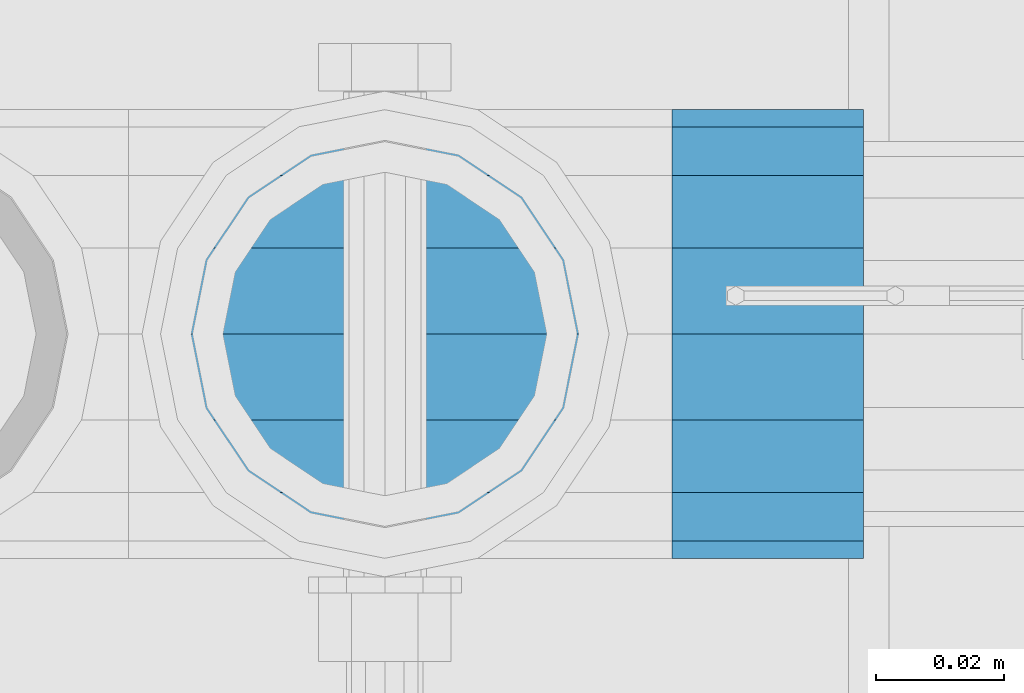
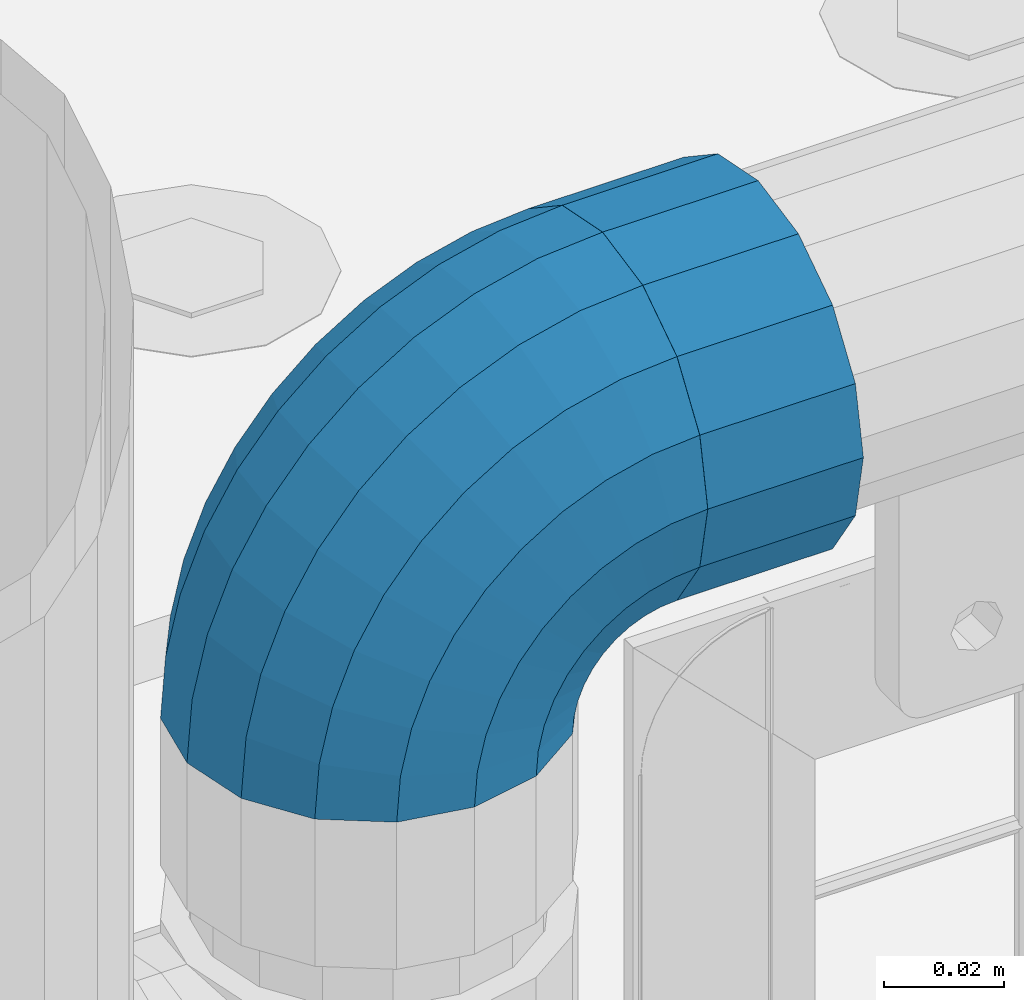
# One storey, part 118 of 208: 1 beam, 1 member.
"""IFC2X3 building model written with IfcOpenShell, lengths in millimetres."""

import ifcopenshell
import ifcopenshell.guid

model = None  # the IFC model being written
_history = None  # IfcOwnerHistory: only IFC2X3 demands one
_inside = {}  # id of a spatial element -> (the spatial element, [elements in it])
_under = {}  # id of a project, library or spatial element -> (it, [spatial elements below it])
_declared = {}  # id of a project -> (the project, [libraries it declares])
_typed = {}  # id of a type object -> (the type object, [elements of that type])
_made_of = {}  # id of a material, layer set ... -> (it, [elements and type objects made of it])


def new_model(schema):
    """Start an empty IFC model of exactly this schema.

    Asked for "IFC4X3", IfcOpenShell would pick the latest addendum, in which some entities
    have other attributes; the version numbers below select the first issue.
    IFC2X3 requires an IfcOwnerHistory on every rooted entity: one is made here for all.
    """
    global model, _history
    if schema == "IFC4X3":
        model = ifcopenshell.file(schema_version=(4, 3, 0, 0))
    else:
        model = ifcopenshell.file(schema=schema)
    _inside.clear()
    _under.clear()
    _declared.clear()
    _typed.clear()
    _made_of.clear()
    _history = None
    if model.schema == "IFC2X3":
        org = make("IfcOrganization", Name="unknown")
        user = make(
            "IfcPersonAndOrganization",
            ThePerson=make("IfcPerson", FamilyName="unknown"),
            TheOrganization=org,
        )
        app = make(
            "IfcApplication",
            ApplicationDeveloper=org,
            Version="unknown",
            ApplicationFullName="unknown",
            ApplicationIdentifier="unknown",
        )
        _history = make(
            "IfcOwnerHistory",
            OwningUser=user,
            OwningApplication=app,
            ChangeAction="ADDED",
            CreationDate=0,
        )
    return model


def make(cls, **values):
    """One entity of the class cls with the attributes given. An attribute that is None is left unset."""
    return model.create_entity(
        cls, **{name: value for name, value in values.items() if value is not None}
    )


def rooted(cls, **values):
    """An entity with a GlobalId (a new one), such as an element, a storey or a relation."""
    return make(cls, GlobalId=ifcopenshell.guid.new(), OwnerHistory=_history, **values)


def si_unit(unit_type, name, prefix=None):
    """IfcSIUnit, for example si_unit("LENGTHUNIT", "METRE", prefix="MILLI")."""
    return make("IfcSIUnit", UnitType=unit_type, Prefix=prefix, Name=name)


def assignment(units):
    """IfcUnitAssignment: the units of a project."""
    return None if units is None else make("IfcUnitAssignment", Units=units)


def point(xyz):
    """IfcCartesianPoint."""
    return None if xyz is None else make("IfcCartesianPoint", Coordinates=xyz)


def direction(xyz):
    """IfcDirection."""
    return None if xyz is None else make("IfcDirection", DirectionRatios=xyz)


def frame(location, z_axis=None, x_axis=None):
    """IfcAxis2Placement3D, a coordinate frame: its origin and axes. An axis left out is left unset."""
    return make(
        "IfcAxis2Placement3D",
        Location=point(location),
        Axis=direction(z_axis),
        RefDirection=direction(x_axis),
    )


def origin_with_axes():
    """The frame at (0, 0, 0) with the z axis (0, 0, 1) and the x axis (1, 0, 0) written out."""
    return frame((0.0, 0.0, 0.0), z_axis=(0.0, 0.0, 1.0), x_axis=(1.0, 0.0, 0.0))


def place(relative_to, where):
    """IfcLocalPlacement: puts the frame where relative to a parent placement (None: the world)."""
    return make(
        "IfcLocalPlacement", PlacementRelTo=relative_to, RelativePlacement=where
    )


def context(
    kind, dimensions, precision=None, world=None, true_north=None, identifier=None
):
    """IfcGeometricRepresentationContext, for example the 3D "Model" context."""
    return make(
        "IfcGeometricRepresentationContext",
        ContextIdentifier=identifier,
        ContextType=kind,
        CoordinateSpaceDimension=dimensions,
        Precision=precision,
        WorldCoordinateSystem=world,
        TrueNorth=true_north,
    )


def subcontext(parent, identifier, kind, view, scale=None):
    """IfcGeometricRepresentationSubContext, for example "Body" below "Model"."""
    return make(
        "IfcGeometricRepresentationSubContext",
        ContextIdentifier=identifier,
        ContextType=kind,
        ParentContext=parent,
        TargetScale=scale,
        TargetView=view,
    )


def project(units=None, contexts=None):
    """IfcProject with its units and contexts."""
    return rooted(
        "IfcProject",
        Name="project",
        RepresentationContexts=contexts,
        UnitsInContext=assignment(units),
    )


def spatial(cls, under=None, at=None, **own):
    """A site, building, storey or space (cls), placed at a placement, below another one or the project."""
    s = rooted(cls, ObjectPlacement=at, **own)
    if under is not None:
        _under.setdefault(under.id(), (under, []))[1].append(s)
    return s


def faces_of(points, faces, orient=None, outer=None):
    """IfcFace entities. A face is a list of loops; a loop is a list of indices into points, from 0.

    orient and outer hold one flag for each loop. By default every Orientation is true, the
    first loop of a face is its IfcFaceOuterBound and the others are IfcFaceBound.
    """
    made = []
    for i, loops in enumerate(faces):
        bounds = []
        for j, loop in enumerate(loops):
            is_outer = j == 0 if outer is None else outer[i][j]
            bounds.append(
                make(
                    "IfcFaceOuterBound" if is_outer else "IfcFaceBound",
                    Bound=make("IfcPolyLoop", Polygon=[points[k] for k in loop]),
                    Orientation=True if orient is None else orient[i][j],
                )
            )
        made.append(make("IfcFace", Bounds=bounds))
    return made


def faceted_brep(points, faces, orient=None, outer=None, voids=None):
    """IfcFacetedBrep: a solid bounded by flat faces; with voids (closed shells), ...WithVoids."""
    shared = [point(p) for p in points]
    hull = make("IfcClosedShell", CfsFaces=faces_of(shared, faces, orient, outer))
    if voids is None:
        return make("IfcFacetedBrep", Outer=hull)
    return make(
        "IfcFacetedBrepWithVoids",
        Outer=hull,
        Voids=[
            make(cls, CfsFaces=faces_of(shared, fs, o, b)) for cls, fs, o, b in voids
        ],
    )


def shape(context_of_items, identifier, shape_type, items):
    """IfcShapeRepresentation: the items that make up one representation, for example the "Body"."""
    return make(
        "IfcShapeRepresentation",
        ContextOfItems=context_of_items,
        RepresentationIdentifier=identifier,
        RepresentationType=shape_type,
        Items=items,
    )


def material(Name=None, Category=None):
    """IfcMaterial."""
    return make("IfcMaterial", Name=Name, Category=Category)


def made_of(thing, what):
    """Note that an element or type object is made of a material, layer set ...; save() writes the relation."""
    if what is not None:
        _made_of.setdefault(what.id(), (what, []))[1].append(thing)
    return thing


def type_object(cls, material=None, **own):
    """A type object (cls), such as IfcWallType, which elements share."""
    return made_of(rooted(cls, **own), material)


def element(
    cls,
    number,
    at=None,
    inside=None,
    cuts=None,
    type_object=None,
    material=None,
    context=None,
    identifier="Body",
    shape_type=None,
    held_by="IfcProductDefinitionShape",
    body=None,
    shapes=None,
    **own,
):
    """One element of the class cls, such as IfcWall. Its Tag is "e" and its number.

    at: its placement. inside: the storey or other place that contains it. cuts: it is an
    opening in that element (IfcRelVoidsElement). A single representation is given by context,
    identifier, shape_type and body (its items); several are given by shapes. held_by: the class
    of the entity that holds the representations. save() writes the other relations.
    """
    e = rooted(cls, Tag="e%d" % number, ObjectPlacement=at, **own)
    if body is not None:
        shapes = [shape(context, identifier, shape_type, body)]
    if shapes is not None:
        e.Representation = make(held_by, Representations=shapes)
    if inside is not None:
        _inside.setdefault(inside.id(), (inside, []))[1].append(e)
    if cuts is not None:
        rooted(
            "IfcRelVoidsElement", RelatingBuildingElement=cuts, RelatedOpeningElement=e
        )
    if type_object is not None:
        _typed.setdefault(type_object.id(), (type_object, []))[1].append(e)
    return made_of(e, material)


def aggregate(whole, parts):
    """IfcRelAggregates: a whole, such as a stair, and the parts it consists of."""
    return rooted("IfcRelAggregates", RelatingObject=whole, RelatedObjects=parts)


def save(model, path):
    """Write the relations noted so far, then the file.

    IfcRelAggregates (storeys below a building ...), IfcRelContainedInSpatialStructure (elements
    in a storey), IfcRelDefinesByType, IfcRelAssociatesMaterial and IfcRelDeclares: one each for
    every whole, place, type object, material and project.
    """
    for whole, parts in _under.values():
        aggregate(whole, parts)
    for where, things in _inside.values():
        rooted(
            "IfcRelContainedInSpatialStructure",
            RelatedElements=things,
            RelatingStructure=where,
        )
    for kind, things in _typed.values():
        rooted("IfcRelDefinesByType", RelatedObjects=things, RelatingType=kind)
    for what, things in _made_of.values():
        rooted("IfcRelAssociatesMaterial", RelatedObjects=things, RelatingMaterial=what)
    for by, libraries in _declared.values():
        rooted("IfcRelDeclares", RelatingContext=by, RelatedDefinitions=libraries)
    model.write(path)


model = new_model("IFC2X3")

# Units and contexts
model_context = context("Model", 3, precision=1e-05, world=origin_with_axes())
body_context = subcontext(model_context, "Body", "Model", "MODEL_VIEW")
ifc_project = project(units=[si_unit("LENGTHUNIT", "METRE", prefix="MILLI"), si_unit("AREAUNIT", "SQUARE_METRE"), si_unit("VOLUMEUNIT", "CUBIC_METRE"), si_unit("MASSUNIT", "GRAM", prefix="KILO"), si_unit("TIMEUNIT", "SECOND"), si_unit("PLANEANGLEUNIT", "RADIAN"), si_unit("SOLIDANGLEUNIT", "STERADIAN"), si_unit("THERMODYNAMICTEMPERATUREUNIT", "DEGREE_CELSIUS"), si_unit("LUMINOUSINTENSITYUNIT", "LUMEN")], contexts=[model_context])

# Site, building, storey
site_placement = place(None, origin_with_axes())
site = spatial("IfcSite", under=ifc_project, at=site_placement, CompositionType="ELEMENT")
building_placement = place(site_placement, origin_with_axes())
building = spatial("IfcBuilding", under=site, at=building_placement, Name="Standard", CompositionType="ELEMENT")
storey_placement = place(building_placement, origin_with_axes())
storey = spatial("IfcBuildingStorey", under=building, at=storey_placement, Name="Undefined", CompositionType="ELEMENT", Elevation=0.0)

# Beam
ifc_material = material(Name="Misc_Undefined")
beam_type = type_object("IfcBeamType", PredefinedType="NOTDEFINED")
beam_placement = place(storey_placement, frame((-41784.0, 4664.5, 969.849999999999), z_axis=(0.0, 0.0, 1.0), x_axis=(1.0, 0.0, 0.0)))
element("IfcBeam", 1, at=beam_placement, inside=storey, type_object=beam_type, material=ifc_material, context=body_context, shape_type="Brep", body=[
    faceted_brep([(0.0, -30.3500000000004, 0.0), (0.0, -28.0397438117179, 11.6144421722784), (30.0, -28.0397438117179, 11.6144421722805), (30.0, -30.3500000000004, 0.0), (0.0, -21.4606908090118, 21.4606908090136), (30.0, -21.4606908090118, 21.4606908090117), (0.0, -11.6144421722802, 28.0397438117143), (30.0, -11.6144421722802, 28.0397438117175), (0.0, 0.0, 30.3499999999985), (30.0, 0.0, 30.35), (0.0, 11.6144421722802, 28.0397438117143), (30.0, 11.6144421722802, 28.0397438117175), (0.0, 21.4606908090118, 21.4606908090136), (30.0, 21.4606908090118, 21.4606908090117), (0.0, 28.0397438117179, 11.6144421722784), (30.0, 28.0397438117179, 11.6144421722805), (0.0, 30.3500000000004, 0.0), (30.0, 30.3500000000004, 0.0), (0.0, 28.0397438117179, -11.6144421722784), (30.0, 28.0397438117179, -11.6144421722805), (0.0, 21.4606908090118, -21.4606908090136), (30.0, 21.4606908090118, -21.4606908090117), (0.0, 11.6144421722802, -28.0397438117143), (30.0, 11.6144421722802, -28.0397438117175), (0.0, 0.0, -30.3499999999985), (30.0, 0.0, -30.35), (0.0, -11.6144421722802, -28.0397438117143), (30.0, -11.6144421722802, -28.0397438117175), (0.0, -21.4606908090118, -21.4606908090136), (30.0, -21.4606908090118, -21.4606908090117), (0.0, -28.0397438117179, -11.6144421722784), (30.0, -28.0397438117179, -11.6144421722805), (0.0, -35.1499999999996, 0.0), (0.0, -32.4743655677721, -13.4513226476338), (30.0, -32.4743655677721, -13.4513226476329), (30.0, -35.1499999999996, 0.0), (0.0, -24.8548033587067, -24.8548033587067), (30.0, -24.8548033587067, -24.8548033587072), (0.0, -13.4513226476329, -32.4743655677739), (30.0, -13.4513226476329, -32.4743655677717), (0.0, 0.0, -35.1499999999996), (30.0, 0.0, -35.15), (0.0, 13.4513226476329, -32.4743655677739), (30.0, 13.4513226476329, -32.4743655677717), (0.0, 24.8548033587067, -24.8548033587067), (30.0, 24.8548033587067, -24.8548033587072), (0.0, 32.4743655677721, -13.4513226476338), (30.0, 32.4743655677721, -13.4513226476329), (0.0, 35.1499999999996, 0.0), (30.0, 35.1499999999996, 0.0), (0.0, 32.4743655677721, 13.4513226476338), (30.0, 32.4743655677721, 13.4513226476329), (0.0, 24.8548033587067, 24.8548033587067), (30.0, 24.8548033587067, 24.8548033587072), (0.0, 13.4513226476329, 32.4743655677739), (30.0, 13.4513226476329, 32.4743655677717), (0.0, 0.0, 35.1499999999996), (30.0, 0.0, 35.15), (0.0, -13.4513226476329, 32.4743655677739), (30.0, -13.4513226476329, 32.4743655677717), (0.0, -24.8548033587067, 24.8548033587067), (30.0, -24.8548033587067, 24.8548033587072), (0.0, -32.4743655677721, 13.4513226476338), (30.0, -32.4743655677721, 13.4513226476329)], [[[0, 1, 2, 3]], [[1, 4, 5, 2]], [[4, 6, 7, 5]], [[6, 8, 9, 7]], [[8, 10, 11, 9]], [[10, 12, 13, 11]], [[12, 14, 15, 13]], [[14, 16, 17, 15]], [[16, 18, 19, 17]], [[18, 20, 21, 19]], [[20, 22, 23, 21]], [[22, 24, 25, 23]], [[24, 26, 27, 25]], [[26, 28, 29, 27]], [[28, 30, 31, 29]], [[30, 0, 3, 31]], [[32, 33, 34, 35]], [[33, 36, 37, 34]], [[36, 38, 39, 37]], [[38, 40, 41, 39]], [[40, 42, 43, 41]], [[42, 44, 45, 43]], [[44, 46, 47, 45]], [[46, 48, 49, 47]], [[48, 50, 51, 49]], [[50, 52, 53, 51]], [[52, 54, 55, 53]], [[54, 56, 57, 55]], [[56, 58, 59, 57]], [[58, 60, 61, 59]], [[60, 62, 63, 61]], [[62, 32, 35, 63]], [[37, 39, 41, 43, 45, 47, 49, 51, 53, 55, 57, 59, 61, 63, 35, 34], [5, 7, 9, 11, 13, 15, 17, 19, 21, 23, 25, 27, 29, 31, 3, 2]], [[62, 60, 58, 56, 54, 52, 50, 48, 46, 44, 42, 40, 38, 36, 33, 32], [30, 28, 26, 24, 22, 20, 18, 16, 14, 12, 10, 8, 6, 4, 1, 0]]]),
])

# Member
member_type = type_object("IfcMemberType", PredefinedType="NOTDEFINED")
member_placement = place(storey_placement, frame((-41829.0, 4664.5, 924.849999999999), z_axis=(-0.707106781186548, 0.0, 0.707106781186548), x_axis=(0.707106781186539, -1.49999999888231e-07, 0.70710678118654)))
element("IfcMember", 2, at=member_placement, inside=storey, type_object=member_type, material=ifc_material, context=body_context, shape_type="Brep", body=[
    faceted_brep([(0.0, -35.1499999999996, 0.0), (9.51152146007371, -32.4743655677721, -9.51152146006643), (13.2759578763435, -32.4743655677721, -6.29638902527222), (5.3694688002397, -35.1499999999996, 4.58595959348168), (17.5750000000044, -24.8548033587067, -17.5749999999971), (19.9787556631163, -24.8548033587067, -15.5219987155615), (22.9628441077075, -13.4513226476329, -22.9628441076966), (24.4574219585302, -13.4513226476329, -21.6863540323902), (24.854803358714, 0.0, -24.8548033587031), (26.0301204183197, 0.0, -23.8509877588003), (22.9628441077075, 13.4513226476329, -22.9628441076966), (24.4574219585302, 13.4513226476329, -21.6863540323902), (17.5750000000044, 24.8548033587067, -17.5749999999971), (19.9787556631163, 24.8548033587067, -15.5219987155615), (9.51152146007371, 32.4743655677721, -9.51152146006643), (13.2759578763435, 32.4743655677721, -6.29638902527222), (0.0, 35.1499999999996, 0.0), (5.3694688002397, 35.1499999999996, 4.58595959348168), (-9.51152146006643, 32.4743655677721, 9.51152146007371), (-2.53702027587133, 32.4743655677721, 15.4683082122356), (-17.5749999999935, 24.8548033587067, 17.5750000000044), (-9.23981806264055, 24.8548033587067, 24.6939179025248), (-22.9628441076966, 13.4513226476329, 22.9628441077039), (-13.7184843580508, 13.4513226476329, 30.8582732193536), (-24.8548033587031, 0.0, 24.854803358714), (-15.2911828178439, 0.0, 33.02290694576), (-22.9628441076966, -13.4513226476329, 22.9628441077039), (-13.7184843580508, -13.4513226476329, 30.8582732193536), (-17.5749999999935, -24.8548033587067, 17.5750000000044), (-9.23981806264055, -24.8548033587067, 24.6939179025248), (-9.51152146006643, -32.4743655677721, 9.51152146007371), (-2.53702027587133, -32.4743655677721, 15.4683082122356), (0.0, -30.3500000000004, 0.0), (-8.21265081971433, -28.0397438117179, 8.21265081972524), (-1.45732902223244, -28.0397438117179, 13.9822406910389), (5.3694688002397, -30.3500000000004, 4.58595959348168), (-15.1749999999956, -21.4606908090118, 15.1750000000029), (-7.24480876130838, -21.4606908090118, 21.9480231689995), (-19.8270929919963, -11.6144421722802, 19.8270929920036), (-11.1118790903529, -11.6144421722802, 27.2705888550809), (-21.4606908090063, 0.0, 21.4606908090136), (-12.46981360684, 0.0, 29.139625372758), (-19.8270929919963, 11.6144421722802, 19.8270929920036), (-11.1118790903529, 11.6144421722802, 27.2705888550809), (-15.1749999999956, 21.4606908090118, 15.1750000000029), (-7.24480876130838, 21.4606908090118, 21.9480231689995), (-8.21265081971433, 28.0397438117179, 8.21265081972524), (-1.45732902223244, 28.0397438117179, 13.9822406910389), (0.0, 30.3500000000004, 0.0), (5.3694688002397, 30.3500000000004, 4.58595959348168), (8.21265081972524, 28.0397438117179, -8.21265081971433), (12.1962666227082, 28.0397438117179, -4.81032150407918), (15.1750000000029, 21.4606908090118, -15.1749999999956), (17.9837463617841, 21.4606908090118, -12.7761039820325), (19.8270929920036, 11.6144421722802, -19.8270929919963), (21.850816690825, 11.6144421722802, -18.0986696681175), (21.4606908090136, 0.0, -21.4606908090063), (23.2087512073158, 0.0, -19.9677061857983), (19.8270929920036, -11.6144421722802, -19.8270929919963), (21.850816690825, -11.6144421722802, -18.0986696681175), (15.1750000000029, -21.4606908090118, -15.1749999999956), (17.9837463617841, -21.4606908090118, -12.7761039820325), (8.21265081972524, -28.0397438117179, -8.21265081971433), (12.1962666227082, -28.0397438117179, -4.81032150407918), (17.4970053560755, -32.4743655677721, -3.70972780291777), (11.3902326651187, -35.1499999999996, 8.27548843508339), (22.6740772628655, -24.8548033587067, -13.870303514941), (26.1332861179544, -13.4513226476329, -20.6593831546779), (27.3479987309656, 0.0, -23.0433908901359), (26.1332861179544, 13.4513226476329, -20.6593831546779), (22.6740772628655, 24.8548033587067, -13.870303514941), (17.4970053560755, 32.4743655677721, -3.70972780291777), (11.3902326651187, 35.1499999999996, 8.27548843508339), (5.28345997416181, 32.4743655677721, 20.2607046730918), (0.106388067368243, 24.8548033587067, 30.4212803851115), (-3.3528207877207, 13.4513226476329, 37.2103600248483), (-4.56753340072828, 0.0, 39.59436776031), (-3.3528207877207, -13.4513226476329, 37.2103600248483), (0.106388067368243, -24.8548033587067, 30.4212803851115), (5.28345997416181, -32.4743655677721, 20.2607046730918), (6.11738625912767, -28.0397438117179, 18.6240321853948), (11.3902326651187, -30.3500000000004, 8.27548843508339), (1.64728291998108, -21.4606908090118, 27.3971039595053), (-1.33954464053022, -11.6144421722802, 33.2590831078996), (-2.38837900197541, 0.0, 35.3175364441995), (-1.33954464053022, 11.6144421722802, 33.2590831078996), (1.64728291998108, 21.4606908090118, 27.3971039595053), (6.11738625912767, 28.0397438117179, 18.6240321853948), (11.3902326651187, 30.3500000000004, 8.27548843508339), (16.663079071106, 28.0397438117179, -2.07305531522434), (21.1331824102563, 21.4606908090118, -10.8461270893349), (24.1200099707712, 11.6144421722802, -16.7081062377256), (25.1688443322128, 0.0, -18.7665595740327), (24.1200099707712, -11.6144421722802, -16.7081062377256), (21.1331824102563, -21.4606908090118, -10.8461270893349), (16.663079071106, -28.0397438117179, -2.07305531522434), (22.0707277014626, -32.4743655677721, -1.81522997692809), (17.9140404065256, -35.1499999999996, 10.9777380798914), (25.5945970362154, -24.8548033587067, -12.6605846156417), (27.9491712485142, -13.4513226476329, -19.9072189058897), (28.7759877588032, 0.0, -22.4518984678834), (27.9491712485142, 13.4513226476329, -19.9072189058897), (25.5945970362154, 24.8548033587067, -12.6605846156417), (22.0707277014626, 32.4743655677721, -1.81522997692809), (17.9140404065256, 35.1499999999996, 10.9777380798914), (13.7573531115886, 32.4743655677721, 23.7707061367109), (10.2334837768358, 24.8548033587067, 34.6160607754246), (7.87890956454066, 13.4513226476329, 41.8626950656726), (7.05209305424796, 0.0, 44.4073746276663), (7.87890956454066, -13.4513226476329, 41.8626950656726), (10.2334837768358, -24.8548033587067, 34.6160607754246), (13.7573531115886, -32.4743655677721, 23.7707061367109), (14.3249803951076, -28.0397438117179, 22.023728990971), (17.9140404065256, -30.3500000000004, 10.9777380798914), (11.2823222355146, -21.4606908090118, 31.3880679180002), (9.2492830507872, -11.6144421722802, 37.6451191472734), (8.53537462724489, 0.0, 39.8423033494473), (9.2492830507872, 11.6144421722802, 37.6451191472734), (11.2823222355146, 21.4606908090118, 31.3880679180002), (14.3249803951076, 28.0397438117179, 22.023728990971), (17.9140404065256, 30.3500000000004, 10.9777380798914), (21.5031004179436, 28.0397438117179, -0.0682528311917849), (24.5457585775366, 21.4606908090118, -9.43259175821368), (26.5787977622676, 11.6144421722802, -15.6896429874905), (27.2927061858063, 0.0, -17.8868271896645), (26.5787977622676, -11.6144421722802, -15.6896429874905), (24.5457585775366, -21.4606908090118, -9.43259175821368), (21.5031004179436, -28.0397438117179, -0.0682528311917849), (26.8845046890528, -32.4743655677721, -0.659544371261291), (24.7802542265854, -35.1499999999996, 12.6261701733893), (28.6684020936882, -24.8548033587067, -11.9226293117899), (29.860364231703, -13.4513226476329, -19.4483820661189), (30.2789256727519, 0.0, -22.0910749985305), (29.860364231703, 13.4513226476329, -19.4483820661189), (28.6684020936882, 24.8548033587067, -11.9226293117899), (26.8845046890528, 32.4743655677721, -0.659544371261291), (24.7802542265854, 35.1499999999996, 12.6261701733893), (22.6760037641179, 32.4743655677721, 25.9118847180434), (20.8921063594898, 24.8548033587067, 37.1749696585721), (19.7001442214714, 13.4513226476329, 44.7007224129011), (19.2815827804225, 0.0, 47.343415345309), (19.7001442214714, -13.4513226476329, 44.7007224129011), (20.8921063594898, -24.8548033587067, 37.1749696585721), (22.6760037641179, -32.4743655677721, 25.9118847180434), (22.9633551786246, -28.0397438117179, 24.0976192894668), (24.7802542265854, -30.3500000000004, 12.6261701733893), (21.4230625404853, -21.4606908090118, 33.8226442665691), (20.3938719035395, -11.6144421722802, 40.3206982094998), (20.0324682126193, 0.0, 42.6025113104552), (20.3938719035395, 11.6144421722802, 40.3206982094998), (21.4230625404853, 21.4606908090118, 33.8226442665691), (22.9633551786246, 28.0397438117179, 24.0976192894668), (24.7802542265854, 30.3500000000004, 12.6261701733893), (26.5971532745498, 28.0397438117179, 1.15472105731169), (28.1374459126891, 21.4606908090118, -8.5703039197906), (29.1666365496385, 11.6144421722802, -15.0683578627177), (29.5280402405588, 0.0, -17.350170963673), (29.1666365496385, -11.6144421722802, -15.0683578627177), (28.1374459126891, -21.4606908090118, -8.5703039197906), (26.5971532745498, -28.0397438117179, 1.15472105731169), (31.8198051533982, -32.4743655677721, -0.271127801024704), (31.8198051533982, -35.1499999999996, 13.1801948466091), (31.8198051533982, -24.8548033587067, -11.6746085120976), (31.8198051533982, -13.4513226476329, -19.2941707211648), (31.8198051533982, 0.0, -21.9698051533924), (31.8198051533982, 13.4513226476329, -19.2941707211648), (31.8198051533982, 24.8548033587067, -11.6746085120976), (31.8198051533982, 32.4743655677721, -0.271127801024704), (31.8198051533982, 35.1499999999996, 13.1801948466091), (31.8198051533982, 32.4743655677721, 26.6315174942429), (31.8198051533982, 24.8548033587067, 38.0349982053158), (31.8198051533946, 13.4513226476329, 45.654560414383), (31.8198051534018, 0.0, 48.3301948466105), (31.8198051533946, -13.4513226476329, 45.654560414383), (31.8198051533982, -24.8548033587067, 38.0349982053158), (31.8198051533982, -32.4743655677721, 26.6315174942429), (31.8198051533982, -28.0397438117179, 24.7946370188874), (31.8198051533982, -30.3500000000004, 13.1801948466091), (31.8198051533982, -21.4606908090118, 34.6408856556227), (31.8198051533982, -11.6144421722802, 41.219938658327), (31.8198051533982, 0.0, 43.5301948466113), (31.8198051533982, 11.6144421722802, 41.219938658327), (31.8198051533982, 21.4606908090118, 34.6408856556227), (31.8198051533982, 28.0397438117179, 24.7946370188874), (31.8198051533982, 30.3500000000004, 13.1801948466091), (31.8198051533946, 28.0397438117179, 1.56575267433072), (31.8198051533982, 21.4606908090118, -8.28049596240453), (31.8198051533982, 11.6144421722802, -14.8595489651088), (31.8198051533982, 0.0, -17.1698051533895), (31.8198051533982, -11.6144421722802, -14.8595489651088), (31.8198051533982, -21.4606908090118, -8.28049596240453), (31.8198051533946, -28.0397438117179, 1.56575267433072), (36.7551056177435, -32.4743655677721, -0.659544371261291), (38.859356080211, -35.1499999999996, 12.6261701733929), (34.9712082131082, -24.8548033587067, -11.9226293117899), (33.7792460750898, -13.4513226476329, -19.4483820661189), (33.3606846340444, 0.0, -22.0910749985269), (33.7792460750898, 13.4513226476329, -19.4483820661189), (34.9712082131082, 24.8548033587067, -11.9226293117899), (36.7551056177435, 32.4743655677721, -0.659544371261291), (38.859356080211, 35.1499999999996, 12.6261701733929), (40.9636065426712, 32.4743655677721, 25.9118847180434), (42.7475039473065, 24.8548033587067, 37.1749696585684), (43.939466085325, 13.4513226476329, 44.7007224129047), (44.3580275263703, 0.0, 47.343415345309), (43.939466085325, -13.4513226476329, 44.7007224129047), (42.7475039473065, -24.8548033587067, 37.1749696585684), (40.9636065426712, -32.4743655677721, 25.9118847180434), (40.6762551281718, -28.0397438117179, 24.0976192894668), (38.859356080211, -30.3500000000004, 12.6261701733929), (42.2165477663111, -21.4606908090118, 33.8226442665691), (43.2457384032568, -11.6144421722802, 40.3206982094998), (43.6071420941771, 0.0, 42.6025113104515), (43.2457384032568, 11.6144421722802, 40.3206982094998), (42.2165477663111, 21.4606908090118, 33.8226442665691), (40.6762551281718, 28.0397438117179, 24.0976192894668), (38.859356080211, 30.3500000000004, 12.6261701733929), (37.0424570322466, 28.0397438117179, 1.15472105731169), (35.5021643941072, 21.4606908090118, -8.5703039197906), (34.4729737571579, 11.6144421722802, -15.0683578627177), (34.1115700662376, 0.0, -17.350170963673), (34.4729737571579, -11.6144421722802, -15.0683578627177), (35.5021643941072, -21.4606908090118, -8.5703039197906), (37.0424570322466, -28.0397438117179, 1.15472105731169), (41.5688826053338, -32.4743655677721, -1.81522997692809), (45.7255699002708, -35.1499999999996, 10.9777380798914), (38.045013270581, -24.8548033587067, -12.6605846156417), (35.6904390582822, -13.4513226476329, -19.9072189058897), (34.8636225479895, 0.0, -22.4518984678834), (35.6904390582822, 13.4513226476329, -19.9072189058897), (38.045013270581, 24.8548033587067, -12.6605846156417), (41.5688826053338, 32.4743655677721, -1.81522997692809), (45.7255699002708, 35.1499999999996, 10.9777380798914), (49.8822571952114, 32.4743655677721, 23.7707061367109), (53.4061265299606, 24.8548033587067, 34.6160607754246), (55.7607007422557, 13.4513226476329, 41.8626950656726), (56.5875172525484, 0.0, 44.4073746276699), (55.7607007422557, -13.4513226476329, 41.8626950656726), (53.4061265299606, -24.8548033587067, 34.6160607754246), (49.8822571952114, -32.4743655677721, 23.7707061367109), (49.3146299116925, -28.0397438117179, 22.0237289909746), (45.7255699002708, -30.3500000000004, 10.9777380798914), (52.3572880712818, -21.4606908090118, 31.3880679179965), (54.3903272560092, -11.6144421722802, 37.6451191472697), (55.1042356795515, 0.0, 39.8423033494473), (54.3903272560092, 11.6144421722802, 37.6451191472697), (52.3572880712818, 21.4606908090118, 31.3880679179965), (49.3146299116925, 28.0397438117179, 22.0237289909746), (45.7255699002708, 30.3500000000004, 10.9777380798914), (42.1365098888527, 28.0397438117179, -0.0682528311917849), (39.0938517292598, 21.4606908090118, -9.43259175821368), (37.0608125445287, 11.6144421722802, -15.6896429874905), (36.3469041209937, 0.0, -17.8868271896645), (37.0608125445287, -11.6144421722802, -15.6896429874905), (39.0938517292598, -21.4606908090118, -9.43259175821368), (42.1365098888527, -28.0397438117179, -0.0682528311917849), (46.1426049507245, -32.4743655677721, -3.70972780291777), (52.2493776416777, -35.1499999999996, 8.27548843508339), (40.9655330439309, -24.8548033587067, -13.870303514941), (37.506324188842, -13.4513226476329, -20.6593831546743), (36.2916115758308, 0.0, -23.0433908901359), (37.506324188842, 13.4513226476329, -20.6593831546743), (40.9655330439309, 24.8548033587067, -13.870303514941), (46.1426049507245, 32.4743655677721, -3.70972780291777), (52.2493776416777, 35.1499999999996, 8.27548843508339), (58.3561503326309, 32.4743655677721, 20.2607046730918), (63.5332222394245, 24.8548033587067, 30.4212803851151), (66.9924310945171, 13.4513226476329, 37.2103600248483), (68.207143707521, 0.0, 39.5943677603063), (66.9924310945171, -13.4513226476329, 37.2103600248483), (63.5332222394245, -24.8548033587067, 30.4212803851151), (58.3561503326309, -32.4743655677721, 20.2607046730918), (57.5222240476687, -28.0397438117179, 18.6240321853984), (52.2493776416777, -30.3500000000004, 8.27548843508339), (61.9923273868153, -21.4606908090118, 27.3971039595053), (64.9791549473266, -11.6144421722802, 33.259083107896), (66.0279893087718, 0.0, 35.3175364442068), (64.9791549473266, 11.6144421722802, 33.259083107896), (61.9923273868153, 21.4606908090118, 27.3971039595053), (57.5222240476687, 28.0397438117179, 18.6240321853984), (52.2493776416777, 30.3500000000004, 8.27548843508339), (46.9765312356867, 28.0397438117179, -2.0730553152207), (42.5064278965401, 21.4606908090118, -10.8461270893349), (39.5196003360288, 11.6144421722802, -16.7081062377256), (38.4707659745836, 0.0, -18.7665595740327), (39.5196003360288, -11.6144421722802, -16.7081062377256), (42.5064278965401, -21.4606908090118, -10.8461270893349), (46.9765312356867, -28.0397438117179, -2.0730553152207), (50.3636524304529, -32.4743655677721, -6.29638902527222), (58.2701415065603, -35.1499999999996, 4.58595959348168), (43.6608546436801, -24.8548033587067, -15.5219987155615), (39.1821883482698, -13.4513226476329, -21.6863540323902), (37.6094898884767, 0.0, -23.8509877587967), (39.1821883482698, 13.4513226476329, -21.6863540323902), (43.6608546436801, 24.8548033587067, -15.5219987155615), (50.3636524304529, 32.4743655677721, -6.29638902527222), (58.2701415065603, 35.1499999999996, 4.58595959348168), (66.1766305826677, 32.4743655677721, 15.4683082122392), (72.8794283694369, 24.8548033587067, 24.6939179025212), (77.3580946648508, 13.4513226476329, 30.8582732193536), (78.9307931246403, 0.0, 33.02290694576), (77.3580946648508, -13.4513226476329, 30.8582732193536), (72.8794283694369, -24.8548033587067, 24.6939179025212), (66.1766305826677, -32.4743655677721, 15.4683082122392), (65.0969393290288, -28.0397438117179, 13.9822406910425), (58.2701415065603, -30.3500000000004, 4.58595959348168), (70.8844190681048, -21.4606908090118, 21.9480231689995), (74.7514893971456, -11.6144421722802, 27.2705888550845), (76.1094239136364, 0.0, 29.1396253727617), (74.7514893971456, 11.6144421722802, 27.2705888550845), (70.8844190681048, 21.4606908090118, 21.9480231689995), (65.0969393290288, 28.0397438117179, 13.9822406910425), (58.2701415065603, 30.3500000000004, 4.58595959348168), (51.4433436840882, 28.0397438117179, -4.81032150407918), (45.6558639450122, 21.4606908090118, -12.7761039820361), (41.7887936159714, 11.6144421722802, -18.0986696681175), (40.4308590994842, 0.0, -19.9677061857983), (41.7887936159714, -11.6144421722802, -18.0986696681175), (45.6558639450122, -21.4606908090118, -12.7761039820361), (51.4433436840882, -28.0397438117179, -4.81032150407918), (54.1280888467227, -32.4743655677721, -9.51152146006643), (63.6396103067927, -35.1499999999996, 3.63797880709171e-12), (46.064610306792, -24.8548033587067, -17.5749999999971), (40.6767661990889, -13.4513226476329, -22.9628441077002), (38.784806948086, 0.0, -24.8548033587031), (40.6767661990889, 13.4513226476329, -22.9628441077002), (46.064610306792, 24.8548033587067, -17.5749999999971), (54.1280888467227, 32.4743655677721, -9.51152146006643), (63.6396103067927, 35.1499999999996, 3.63797880709171e-12), (73.1511317668628, 32.4743655677721, 9.51152146007371), (81.2146103067935, 24.8548033587067, 17.5750000000044), (86.602454414493, 13.4513226476329, 22.9628441077075), (88.4944136654995, 0.0, 24.8548033587103), (86.602454414493, -13.4513226476329, 22.9628441077075), (81.2146103067935, -24.8548033587067, 17.5750000000044), (73.1511317668628, -32.4743655677721, 9.51152146007371), (71.8522611265107, -28.0397438117179, 8.2126508197216), (63.6396103067927, -30.3500000000004, 3.63797880709171e-12), (78.814610306792, -21.4606908090118, 15.1750000000029), (83.4667032987927, -11.6144421722802, 19.8270929920036), (85.1003011158027, 0.0, 21.4606908090136), (83.4667032987927, 11.6144421722802, 19.8270929920036), (78.814610306792, 21.4606908090118, 15.1750000000029), (71.8522611265107, 28.0397438117179, 8.2126508197216), (63.6396103067927, 30.3500000000004, 3.63797880709171e-12), (55.4269594870748, 28.0397438117179, -8.21265081971433), (48.4646103067935, 21.4606908090118, -15.1749999999956), (43.8125173147928, 11.6144421722802, -19.8270929919963), (42.1789194977791, 0.0, -21.4606908090063), (43.8125173147928, -11.6144421722802, -19.8270929919963), (48.4646103067935, -21.4606908090118, -15.1749999999956), (55.4269594870748, -28.0397438117179, -8.21265081971433)], [[[0, 1, 2, 3]], [[1, 4, 5, 2]], [[4, 6, 7, 5]], [[6, 8, 9, 7]], [[8, 10, 11, 9]], [[10, 12, 13, 11]], [[12, 14, 15, 13]], [[14, 16, 17, 15]], [[16, 18, 19, 17]], [[18, 20, 21, 19]], [[20, 22, 23, 21]], [[22, 24, 25, 23]], [[24, 26, 27, 25]], [[26, 28, 29, 27]], [[28, 30, 31, 29]], [[30, 0, 3, 31]], [[32, 33, 34, 35]], [[33, 36, 37, 34]], [[36, 38, 39, 37]], [[38, 40, 41, 39]], [[40, 42, 43, 41]], [[42, 44, 45, 43]], [[44, 46, 47, 45]], [[46, 48, 49, 47]], [[48, 50, 51, 49]], [[50, 52, 53, 51]], [[52, 54, 55, 53]], [[54, 56, 57, 55]], [[56, 58, 59, 57]], [[58, 60, 61, 59]], [[60, 62, 63, 61]], [[62, 32, 35, 63]], [[30, 28, 26, 24, 22, 20, 18, 16, 14, 12, 10, 8, 6, 4, 1, 0], [62, 60, 58, 56, 54, 52, 50, 48, 46, 44, 42, 40, 38, 36, 33, 32]], [[3, 2, 64, 65]], [[2, 5, 66, 64]], [[5, 7, 67, 66]], [[7, 9, 68, 67]], [[9, 11, 69, 68]], [[11, 13, 70, 69]], [[13, 15, 71, 70]], [[15, 17, 72, 71]], [[17, 19, 73, 72]], [[19, 21, 74, 73]], [[21, 23, 75, 74]], [[23, 25, 76, 75]], [[25, 27, 77, 76]], [[27, 29, 78, 77]], [[29, 31, 79, 78]], [[31, 3, 65, 79]], [[35, 34, 80, 81]], [[34, 37, 82, 80]], [[37, 39, 83, 82]], [[39, 41, 84, 83]], [[41, 43, 85, 84]], [[43, 45, 86, 85]], [[45, 47, 87, 86]], [[47, 49, 88, 87]], [[49, 51, 89, 88]], [[51, 53, 90, 89]], [[53, 55, 91, 90]], [[55, 57, 92, 91]], [[57, 59, 93, 92]], [[59, 61, 94, 93]], [[61, 63, 95, 94]], [[63, 35, 81, 95]], [[65, 64, 96, 97]], [[64, 66, 98, 96]], [[66, 67, 99, 98]], [[67, 68, 100, 99]], [[68, 69, 101, 100]], [[69, 70, 102, 101]], [[70, 71, 103, 102]], [[71, 72, 104, 103]], [[72, 73, 105, 104]], [[73, 74, 106, 105]], [[74, 75, 107, 106]], [[75, 76, 108, 107]], [[76, 77, 109, 108]], [[77, 78, 110, 109]], [[78, 79, 111, 110]], [[79, 65, 97, 111]], [[81, 80, 112, 113]], [[80, 82, 114, 112]], [[82, 83, 115, 114]], [[83, 84, 116, 115]], [[84, 85, 117, 116]], [[85, 86, 118, 117]], [[86, 87, 119, 118]], [[87, 88, 120, 119]], [[88, 89, 121, 120]], [[89, 90, 122, 121]], [[90, 91, 123, 122]], [[91, 92, 124, 123]], [[92, 93, 125, 124]], [[93, 94, 126, 125]], [[94, 95, 127, 126]], [[95, 81, 113, 127]], [[97, 96, 128, 129]], [[96, 98, 130, 128]], [[98, 99, 131, 130]], [[99, 100, 132, 131]], [[100, 101, 133, 132]], [[101, 102, 134, 133]], [[102, 103, 135, 134]], [[103, 104, 136, 135]], [[104, 105, 137, 136]], [[105, 106, 138, 137]], [[106, 107, 139, 138]], [[107, 108, 140, 139]], [[108, 109, 141, 140]], [[109, 110, 142, 141]], [[110, 111, 143, 142]], [[111, 97, 129, 143]], [[113, 112, 144, 145]], [[112, 114, 146, 144]], [[114, 115, 147, 146]], [[115, 116, 148, 147]], [[116, 117, 149, 148]], [[117, 118, 150, 149]], [[118, 119, 151, 150]], [[119, 120, 152, 151]], [[120, 121, 153, 152]], [[121, 122, 154, 153]], [[122, 123, 155, 154]], [[123, 124, 156, 155]], [[124, 125, 157, 156]], [[125, 126, 158, 157]], [[126, 127, 159, 158]], [[127, 113, 145, 159]], [[129, 128, 160, 161]], [[128, 130, 162, 160]], [[130, 131, 163, 162]], [[131, 132, 164, 163]], [[132, 133, 165, 164]], [[133, 134, 166, 165]], [[134, 135, 167, 166]], [[135, 136, 168, 167]], [[136, 137, 169, 168]], [[137, 138, 170, 169]], [[138, 139, 171, 170]], [[139, 140, 172, 171]], [[140, 141, 173, 172]], [[141, 142, 174, 173]], [[142, 143, 175, 174]], [[143, 129, 161, 175]], [[145, 144, 176, 177]], [[144, 146, 178, 176]], [[146, 147, 179, 178]], [[147, 148, 180, 179]], [[148, 149, 181, 180]], [[149, 150, 182, 181]], [[150, 151, 183, 182]], [[151, 152, 184, 183]], [[152, 153, 185, 184]], [[153, 154, 186, 185]], [[154, 155, 187, 186]], [[155, 156, 188, 187]], [[156, 157, 189, 188]], [[157, 158, 190, 189]], [[158, 159, 191, 190]], [[159, 145, 177, 191]], [[161, 160, 192, 193]], [[160, 162, 194, 192]], [[162, 163, 195, 194]], [[163, 164, 196, 195]], [[164, 165, 197, 196]], [[165, 166, 198, 197]], [[166, 167, 199, 198]], [[167, 168, 200, 199]], [[168, 169, 201, 200]], [[169, 170, 202, 201]], [[170, 171, 203, 202]], [[171, 172, 204, 203]], [[172, 173, 205, 204]], [[173, 174, 206, 205]], [[174, 175, 207, 206]], [[175, 161, 193, 207]], [[177, 176, 208, 209]], [[176, 178, 210, 208]], [[178, 179, 211, 210]], [[179, 180, 212, 211]], [[180, 181, 213, 212]], [[181, 182, 214, 213]], [[182, 183, 215, 214]], [[183, 184, 216, 215]], [[184, 185, 217, 216]], [[185, 186, 218, 217]], [[186, 187, 219, 218]], [[187, 188, 220, 219]], [[188, 189, 221, 220]], [[189, 190, 222, 221]], [[190, 191, 223, 222]], [[191, 177, 209, 223]], [[193, 192, 224, 225]], [[192, 194, 226, 224]], [[194, 195, 227, 226]], [[195, 196, 228, 227]], [[196, 197, 229, 228]], [[197, 198, 230, 229]], [[198, 199, 231, 230]], [[199, 200, 232, 231]], [[200, 201, 233, 232]], [[201, 202, 234, 233]], [[202, 203, 235, 234]], [[203, 204, 236, 235]], [[204, 205, 237, 236]], [[205, 206, 238, 237]], [[206, 207, 239, 238]], [[207, 193, 225, 239]], [[209, 208, 240, 241]], [[208, 210, 242, 240]], [[210, 211, 243, 242]], [[211, 212, 244, 243]], [[212, 213, 245, 244]], [[213, 214, 246, 245]], [[214, 215, 247, 246]], [[215, 216, 248, 247]], [[216, 217, 249, 248]], [[217, 218, 250, 249]], [[218, 219, 251, 250]], [[219, 220, 252, 251]], [[220, 221, 253, 252]], [[221, 222, 254, 253]], [[222, 223, 255, 254]], [[223, 209, 241, 255]], [[225, 224, 256, 257]], [[224, 226, 258, 256]], [[226, 227, 259, 258]], [[227, 228, 260, 259]], [[228, 229, 261, 260]], [[229, 230, 262, 261]], [[230, 231, 263, 262]], [[231, 232, 264, 263]], [[232, 233, 265, 264]], [[233, 234, 266, 265]], [[234, 235, 267, 266]], [[235, 236, 268, 267]], [[236, 237, 269, 268]], [[237, 238, 270, 269]], [[238, 239, 271, 270]], [[239, 225, 257, 271]], [[241, 240, 272, 273]], [[240, 242, 274, 272]], [[242, 243, 275, 274]], [[243, 244, 276, 275]], [[244, 245, 277, 276]], [[245, 246, 278, 277]], [[246, 247, 279, 278]], [[247, 248, 280, 279]], [[248, 249, 281, 280]], [[249, 250, 282, 281]], [[250, 251, 283, 282]], [[251, 252, 284, 283]], [[252, 253, 285, 284]], [[253, 254, 286, 285]], [[254, 255, 287, 286]], [[255, 241, 273, 287]], [[257, 256, 288, 289]], [[256, 258, 290, 288]], [[258, 259, 291, 290]], [[259, 260, 292, 291]], [[260, 261, 293, 292]], [[261, 262, 294, 293]], [[262, 263, 295, 294]], [[263, 264, 296, 295]], [[264, 265, 297, 296]], [[265, 266, 298, 297]], [[266, 267, 299, 298]], [[267, 268, 300, 299]], [[268, 269, 301, 300]], [[269, 270, 302, 301]], [[270, 271, 303, 302]], [[271, 257, 289, 303]], [[273, 272, 304, 305]], [[272, 274, 306, 304]], [[274, 275, 307, 306]], [[275, 276, 308, 307]], [[276, 277, 309, 308]], [[277, 278, 310, 309]], [[278, 279, 311, 310]], [[279, 280, 312, 311]], [[280, 281, 313, 312]], [[281, 282, 314, 313]], [[282, 283, 315, 314]], [[283, 284, 316, 315]], [[284, 285, 317, 316]], [[285, 286, 318, 317]], [[286, 287, 319, 318]], [[287, 273, 305, 319]], [[289, 288, 320, 321]], [[288, 290, 322, 320]], [[290, 291, 323, 322]], [[291, 292, 324, 323]], [[292, 293, 325, 324]], [[293, 294, 326, 325]], [[294, 295, 327, 326]], [[295, 296, 328, 327]], [[296, 297, 329, 328]], [[297, 298, 330, 329]], [[298, 299, 331, 330]], [[299, 300, 332, 331]], [[300, 301, 333, 332]], [[301, 302, 334, 333]], [[302, 303, 335, 334]], [[303, 289, 321, 335]], [[305, 304, 336, 337]], [[304, 306, 338, 336]], [[306, 307, 339, 338]], [[307, 308, 340, 339]], [[308, 309, 341, 340]], [[309, 310, 342, 341]], [[310, 311, 343, 342]], [[311, 312, 344, 343]], [[312, 313, 345, 344]], [[313, 314, 346, 345]], [[314, 315, 347, 346]], [[315, 316, 348, 347]], [[316, 317, 349, 348]], [[317, 318, 350, 349]], [[318, 319, 351, 350]], [[319, 305, 337, 351]], [[322, 323, 324, 325, 326, 327, 328, 329, 330, 331, 332, 333, 334, 335, 321, 320], [338, 339, 340, 341, 342, 343, 344, 345, 346, 347, 348, 349, 350, 351, 337, 336]]]),
])

save(model, "model.ifc")
